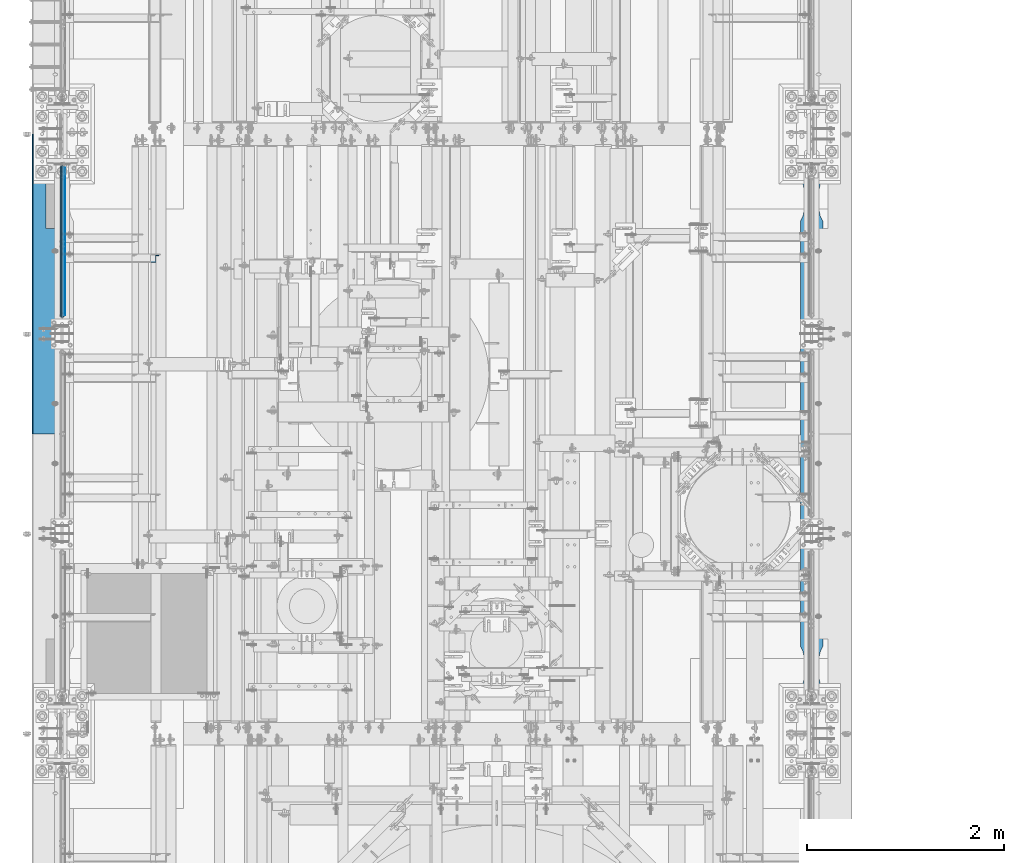
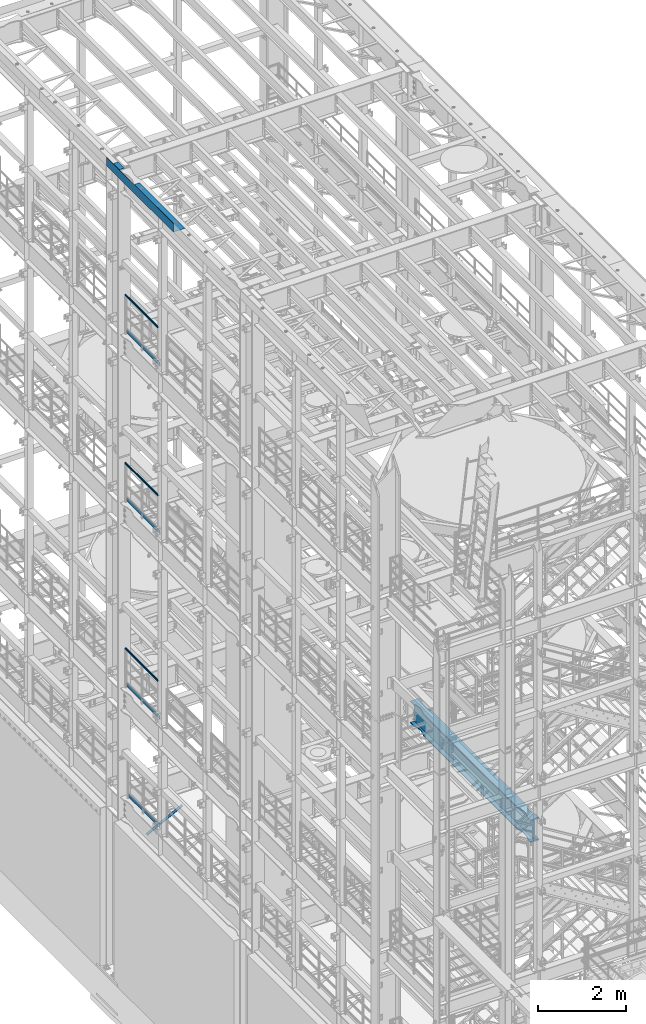
# One storey, part 1040 of 1876: 9 beams, 1 member, 7 elements without a shape of their own.
"""IFC2X3 building model written with IfcOpenShell, lengths in millimetres."""

from ifc_helpers import new_model, si_unit, frame, origin_with_axes, place, context, subcontext, project, spatial, faceted_brep, material, type_object, element, aggregate, save


model = new_model("IFC2X3")

# Units and contexts
model_context = context("Model", 3, precision=1e-05, world=origin_with_axes())
body_context = subcontext(model_context, "Body", "Model", "MODEL_VIEW")
ifc_project = project(units=[si_unit("LENGTHUNIT", "METRE", prefix="MILLI"), si_unit("AREAUNIT", "SQUARE_METRE"), si_unit("VOLUMEUNIT", "CUBIC_METRE"), si_unit("MASSUNIT", "GRAM", prefix="KILO"), si_unit("TIMEUNIT", "SECOND"), si_unit("PLANEANGLEUNIT", "RADIAN"), si_unit("SOLIDANGLEUNIT", "STERADIAN"), si_unit("THERMODYNAMICTEMPERATUREUNIT", "DEGREE_CELSIUS"), si_unit("LUMINOUSINTENSITYUNIT", "LUMEN")], contexts=[model_context])

# Site, building, storey
site_placement = place(None, origin_with_axes())
site = spatial("IfcSite", under=ifc_project, at=site_placement, CompositionType="ELEMENT")
building_placement = place(site_placement, origin_with_axes())
building = spatial("IfcBuilding", under=site, at=building_placement, Name="Undefined", CompositionType="ELEMENT")
storey_placement = place(building_placement, origin_with_axes())
storey = spatial("IfcBuildingStorey", under=building, at=storey_placement, Name="Undefined", CompositionType="ELEMENT", Elevation=0.0)

# Assembly, beam
assembly_1_placement = place(storey_placement, origin_with_axes())
assembly_1 = element("IfcElementAssembly", 1, at=assembly_1_placement, inside=storey, Name="RAIL", AssemblyPlace="NOTDEFINED", PredefinedType="RIGID_FRAME")
ifc_material_1 = material()
beam_type_1 = type_object("IfcBeamType", Name="PIPE1-1/2SCH40", PredefinedType="NOTDEFINED")
beam_1_placement = place(assembly_1_placement, frame((-1.81898940354586e-12, 5753.1, 19059.525), z_axis=(0.0, 0.0, -1.0), x_axis=(0.0, 1.0, 0.0)))
beam_1 = element("IfcBeam", 2, at=beam_1_placement, type_object=beam_type_1, material=ifc_material_1, Name="RAIL", ObjectType="PIPE1-1/2SCH40", context=body_context, shape_type="Brep", body=[
    faceted_brep([(24.1300000000001, -20.4469999999999, 0.0), (34.3535000000002, -17.7076214311803, 10.2235000000001), (1511.8715, -17.7076214311801, 10.2235000000001), (1522.095, -20.4470000000001, 0.0), (41.8376214311802, -10.2235000000001, 17.7076214311819), (1504.38737856882, -10.2235000000001, 17.7076214311819), (44.5770000000002, 0.0, 20.4470000000001), (1501.648, 0.0, 20.4470000000001), (41.8376214311802, 10.2235000000001, 17.7076214311819), (1504.38737856882, 10.2235000000001, 17.7076214311819), (34.3535000000002, 17.7076214311803, 10.2235000000001), (1511.8715, 17.7076214311801, 10.2235000000001), (24.1300000000001, 20.4469999999999, 0.0), (1522.095, 20.4470000000001, 0.0), (13.9065000000001, 17.7076214311803, -10.2235000000001), (1532.3185, 17.7076214311801, -10.2235000000001), (6.42237856882002, 10.2235000000001, -17.7076214311819), (1539.80262143118, 10.2235000000001, -17.7076214311819), (3.68299999999999, 0.0, -20.4470000000001), (1542.542, 0.0, -20.4470000000001), (6.42237856882002, -10.2235000000001, -17.7076214311819), (1539.80262143118, -10.2235000000001, -17.7076214311819), (13.9065000000001, -17.7076214311803, -10.2235000000001), (1532.3185, -17.7076214311801, -10.2235000000001), (24.1299999999854, -24.1299999999992, 0.0), (12.0650000000064, -20.8971929933177, -12.0649999999987), (1534.16, -20.8971929933186, -12.0649999999987), (1522.095, -24.1300000000001, 0.0), (3.23280700668147, -12.0650000000001, -20.8971929933177), (1542.99219299332, -12.0649999999996, -20.8971929933177), (-1.45519152283669e-11, 0.0, -24.130000000001), (1546.225, 0.0, -24.130000000001), (3.23280700668147, 12.0650000000001, -20.8971929933177), (1542.99219299332, 12.0649999999996, -20.8971929933177), (12.0650000000064, 20.8971929933177, -12.0649999999987), (1534.16, 20.8971929933186, -12.0649999999987), (24.1300000000047, 24.1299999999992, 0.0), (1522.095, 24.1300000000001, 0.0), (36.1949999999997, 20.8971929933184, 12.0649999999987), (1510.03, 20.8971929933186, 12.0649999999987), (45.0271929933187, 12.0650000000001, 20.8971929933177), (1501.19780700668, 12.0649999999996, 20.8971929933177), (48.2600000000002, 0.0, 24.130000000001), (1497.965, 0.0, 24.130000000001), (45.0271929933187, -12.0650000000001, 20.8971929933177), (1501.19780700668, -12.0649999999996, 20.8971929933177), (36.1949999999997, -20.8971929933184, 12.0649999999987), (1510.03, -20.8971929933186, 12.0649999999987)], [[[0, 1, 2, 3]], [[1, 4, 5, 2]], [[4, 6, 7, 5]], [[6, 8, 9, 7]], [[8, 10, 11, 9]], [[10, 12, 13, 11]], [[12, 14, 15, 13]], [[14, 16, 17, 15]], [[16, 18, 19, 17]], [[18, 20, 21, 19]], [[20, 22, 23, 21]], [[22, 0, 3, 23]], [[24, 25, 26, 27]], [[25, 28, 29, 26]], [[28, 30, 31, 29]], [[30, 32, 33, 31]], [[32, 34, 35, 33]], [[34, 36, 37, 35]], [[36, 38, 39, 37]], [[38, 40, 41, 39]], [[40, 42, 43, 41]], [[42, 44, 45, 43]], [[44, 46, 47, 45]], [[46, 24, 27, 47]], [[29, 31, 33, 35, 37, 39, 41, 43, 45, 47, 27, 26], [5, 7, 9, 11, 13, 15, 17, 19, 21, 23, 3, 2]], [[46, 44, 42, 40, 38, 36, 34, 32, 30, 28, 25, 24], [22, 20, 18, 16, 14, 12, 10, 8, 6, 4, 1, 0]]]),
])

assembly_2_placement = place(storey_placement, origin_with_axes())
assembly_2 = element("IfcElementAssembly", 3, at=assembly_2_placement, inside=storey, Name="RAIL", AssemblyPlace="NOTDEFINED", PredefinedType="RIGID_FRAME")
beam_2_placement = place(assembly_2_placement, frame((-1.81898940354586e-12, 5753.1, 14385.925), z_axis=(0.0, 0.0, -1.0), x_axis=(0.0, 1.0, 0.0)))
beam_2 = element("IfcBeam", 4, at=beam_2_placement, type_object=beam_type_1, material=ifc_material_1, Name="RAIL", ObjectType="PIPE1-1/2SCH40", context=body_context, shape_type="Brep", body=[
    faceted_brep([(24.1300000000001, -20.4469999999999, 0.0), (34.3535000000002, -17.7076214311803, 10.2235000000001), (1511.8715, -17.7076214311801, 10.2235000000001), (1522.095, -20.4470000000001, 0.0), (41.8376214311802, -10.2235000000001, 17.7076214311819), (1504.38737856882, -10.2235000000001, 17.7076214311819), (44.5770000000002, 0.0, 20.4470000000001), (1501.648, 0.0, 20.4470000000001), (41.8376214311802, 10.2235000000001, 17.7076214311819), (1504.38737856882, 10.2235000000001, 17.7076214311819), (34.3535000000002, 17.7076214311803, 10.2235000000001), (1511.8715, 17.7076214311801, 10.2235000000001), (24.1300000000001, 20.4469999999999, 0.0), (1522.095, 20.4470000000001, 0.0), (13.9065000000001, 17.7076214311803, -10.2235000000001), (1532.3185, 17.7076214311801, -10.2235000000001), (6.42237856882002, 10.2235000000001, -17.7076214311819), (1539.80262143118, 10.2235000000001, -17.7076214311819), (3.68299999999999, 0.0, -20.4470000000001), (1542.542, 0.0, -20.4470000000001), (6.42237856882002, -10.2235000000001, -17.7076214311819), (1539.80262143118, -10.2235000000001, -17.7076214311819), (13.9065000000001, -17.7076214311803, -10.2235000000001), (1532.3185, -17.7076214311801, -10.2235000000001), (24.1299999999854, -24.1299999999992, 0.0), (12.0650000000064, -20.8971929933177, -12.0649999999987), (1534.16, -20.8971929933186, -12.0649999999987), (1522.095, -24.1300000000001, 0.0), (3.23280700668147, -12.0650000000001, -20.8971929933177), (1542.99219299332, -12.0649999999996, -20.8971929933177), (-1.45519152283669e-11, 0.0, -24.130000000001), (1546.225, 0.0, -24.130000000001), (3.23280700668147, 12.0650000000001, -20.8971929933177), (1542.99219299332, 12.0649999999996, -20.8971929933177), (12.0650000000064, 20.8971929933177, -12.0649999999987), (1534.16, 20.8971929933186, -12.0649999999987), (24.1300000000047, 24.1299999999992, 0.0), (1522.095, 24.1300000000001, 0.0), (36.1949999999997, 20.8971929933184, 12.0649999999987), (1510.03, 20.8971929933186, 12.0649999999987), (45.0271929933187, 12.0650000000001, 20.8971929933177), (1501.19780700668, 12.0649999999996, 20.8971929933177), (48.2600000000002, 0.0, 24.130000000001), (1497.965, 0.0, 24.130000000001), (45.0271929933187, -12.0650000000001, 20.8971929933177), (1501.19780700668, -12.0649999999996, 20.8971929933177), (36.1949999999997, -20.8971929933184, 12.0649999999987), (1510.03, -20.8971929933186, 12.0649999999987)], [[[0, 1, 2, 3]], [[1, 4, 5, 2]], [[4, 6, 7, 5]], [[6, 8, 9, 7]], [[8, 10, 11, 9]], [[10, 12, 13, 11]], [[12, 14, 15, 13]], [[14, 16, 17, 15]], [[16, 18, 19, 17]], [[18, 20, 21, 19]], [[20, 22, 23, 21]], [[22, 0, 3, 23]], [[24, 25, 26, 27]], [[25, 28, 29, 26]], [[28, 30, 31, 29]], [[30, 32, 33, 31]], [[32, 34, 35, 33]], [[34, 36, 37, 35]], [[36, 38, 39, 37]], [[38, 40, 41, 39]], [[40, 42, 43, 41]], [[42, 44, 45, 43]], [[44, 46, 47, 45]], [[46, 24, 27, 47]], [[29, 31, 33, 35, 37, 39, 41, 43, 45, 47, 27, 26], [5, 7, 9, 11, 13, 15, 17, 19, 21, 23, 3, 2]], [[46, 44, 42, 40, 38, 36, 34, 32, 30, 28, 25, 24], [22, 20, 18, 16, 14, 12, 10, 8, 6, 4, 1, 0]]]),
])

assembly_3_placement = place(storey_placement, origin_with_axes())
assembly_3 = element("IfcElementAssembly", 5, at=assembly_3_placement, inside=storey, Name="RAIL", AssemblyPlace="NOTDEFINED", PredefinedType="RIGID_FRAME")
beam_3_placement = place(assembly_3_placement, frame((-1.81898940354586e-12, 5753.1, 9229.725), z_axis=(0.0, 0.0, -1.0), x_axis=(0.0, 1.0, 0.0)))
beam_3 = element("IfcBeam", 6, at=beam_3_placement, type_object=beam_type_1, material=ifc_material_1, Name="RAIL", ObjectType="PIPE1-1/2SCH40", context=body_context, shape_type="Brep", body=[
    faceted_brep([(24.1300000000001, -20.4469999999999, 0.0), (34.3535000000002, -17.7076214311803, 10.2235000000001), (1511.8715, -17.7076214311801, 10.2235000000001), (1522.095, -20.4470000000001, 0.0), (41.8376214311802, -10.2235000000001, 17.7076214311819), (1504.38737856882, -10.2235000000001, 17.7076214311819), (44.5770000000002, 0.0, 20.4470000000001), (1501.648, 0.0, 20.4470000000001), (41.8376214311802, 10.2235000000001, 17.7076214311819), (1504.38737856882, 10.2235000000001, 17.7076214311819), (34.3535000000002, 17.7076214311803, 10.2235000000001), (1511.8715, 17.7076214311801, 10.2235000000001), (24.1300000000001, 20.4469999999999, 0.0), (1522.095, 20.4470000000001, 0.0), (13.9065000000001, 17.7076214311803, -10.2235000000001), (1532.3185, 17.7076214311801, -10.2235000000001), (6.42237856882002, 10.2235000000001, -17.7076214311819), (1539.80262143118, 10.2235000000001, -17.7076214311819), (3.68299999999999, 0.0, -20.4470000000001), (1542.542, 0.0, -20.4470000000001), (6.42237856882002, -10.2235000000001, -17.7076214311819), (1539.80262143118, -10.2235000000001, -17.7076214311819), (13.9065000000001, -17.7076214311803, -10.2235000000001), (1532.3185, -17.7076214311801, -10.2235000000001), (24.1299999999854, -24.1299999999992, 0.0), (12.0650000000064, -20.8971929933177, -12.0649999999987), (1534.16, -20.8971929933186, -12.0649999999987), (1522.095, -24.1300000000001, 0.0), (3.23280700668147, -12.0650000000001, -20.8971929933177), (1542.99219299332, -12.0649999999996, -20.8971929933177), (-1.45519152283669e-11, 0.0, -24.130000000001), (1546.225, 0.0, -24.130000000001), (3.23280700668147, 12.0650000000001, -20.8971929933177), (1542.99219299332, 12.0649999999996, -20.8971929933177), (12.0650000000064, 20.8971929933177, -12.0649999999987), (1534.16, 20.8971929933186, -12.0649999999987), (24.1300000000047, 24.1299999999992, 0.0), (1522.095, 24.1300000000001, 0.0), (36.1949999999997, 20.8971929933184, 12.0649999999987), (1510.03, 20.8971929933186, 12.0649999999987), (45.0271929933187, 12.0650000000001, 20.8971929933177), (1501.19780700668, 12.0649999999996, 20.8971929933177), (48.2600000000002, 0.0, 24.130000000001), (1497.965, 0.0, 24.130000000001), (45.0271929933187, -12.0650000000001, 20.8971929933177), (1501.19780700668, -12.0649999999996, 20.8971929933177), (36.1949999999997, -20.8971929933184, 12.0649999999987), (1510.03, -20.8971929933186, 12.0649999999987)], [[[0, 1, 2, 3]], [[1, 4, 5, 2]], [[4, 6, 7, 5]], [[6, 8, 9, 7]], [[8, 10, 11, 9]], [[10, 12, 13, 11]], [[12, 14, 15, 13]], [[14, 16, 17, 15]], [[16, 18, 19, 17]], [[18, 20, 21, 19]], [[20, 22, 23, 21]], [[22, 0, 3, 23]], [[24, 25, 26, 27]], [[25, 28, 29, 26]], [[28, 30, 31, 29]], [[30, 32, 33, 31]], [[32, 34, 35, 33]], [[34, 36, 37, 35]], [[36, 38, 39, 37]], [[38, 40, 41, 39]], [[40, 42, 43, 41]], [[42, 44, 45, 43]], [[44, 46, 47, 45]], [[46, 24, 27, 47]], [[29, 31, 33, 35, 37, 39, 41, 43, 45, 47, 27, 26], [5, 7, 9, 11, 13, 15, 17, 19, 21, 23, 3, 2]], [[46, 44, 42, 40, 38, 36, 34, 32, 30, 28, 25, 24], [22, 20, 18, 16, 14, 12, 10, 8, 6, 4, 1, 0]]]),
])

# Beam
ifc_material_2 = material(Name="STEEL/A36")
beam_type_2 = type_object("IfcBeamType", PredefinedType="NOTDEFINED")
beam_4_placement = place(assembly_1_placement, frame((27.3049999999948, 5777.23, 18049.8809122948), z_axis=(0.0, 0.0, 1.0), x_axis=(0.0, 1.0, 0.0)))
beam_4 = element("IfcBeam", 7, at=beam_4_placement, type_object=beam_type_2, material=ifc_material_2, Name="PLATE", context=body_context, shape_type="Brep", body=[
    faceted_brep([(0.0, 3.17500000000018, -50.8000000000002), (0.0, 3.17500000000018, 50.8000000000002), (1497.965, 3.175, 50.7999999999993), (1497.965, 3.175, -50.7999999999993), (0.0, -3.17500000000018, 50.8000000000002), (1497.965, -3.175, 50.7999999999993), (0.0, -3.17500000000018, -50.8000000000002), (1497.965, -3.175, -50.7999999999993)], [[[0, 1, 2, 3]], [[1, 4, 5, 2]], [[4, 6, 7, 5]], [[6, 0, 3, 7]], [[5, 7, 3, 2]], [[6, 4, 1, 0]]]),
])

aggregate(assembly_1, [beam_4, beam_1])

beam_5_placement = place(assembly_2_placement, frame((27.3049999999948, 5777.23, 13376.2809122948), z_axis=(0.0, 0.0, 1.0), x_axis=(0.0, 1.0, 0.0)))
beam_5 = element("IfcBeam", 8, at=beam_5_placement, type_object=beam_type_2, material=ifc_material_2, Name="PLATE", context=body_context, shape_type="Brep", body=[
    faceted_brep([(0.0, 3.17500000000018, -50.8000000000002), (0.0, 3.17500000000018, 50.8000000000002), (1497.965, 3.175, 50.7999999999993), (1497.965, 3.175, -50.7999999999993), (0.0, -3.17500000000018, 50.8000000000002), (1497.965, -3.175, 50.7999999999993), (0.0, -3.17500000000018, -50.8000000000002), (1497.965, -3.175, -50.7999999999993)], [[[0, 1, 2, 3]], [[1, 4, 5, 2]], [[4, 6, 7, 5]], [[6, 0, 3, 7]], [[5, 7, 3, 2]], [[6, 4, 1, 0]]]),
])

aggregate(assembly_2, [beam_5, beam_2])

beam_6_placement = place(assembly_3_placement, frame((27.3049999999948, 5777.23, 8220.08091229478), z_axis=(0.0, 0.0, 1.0), x_axis=(0.0, 1.0, 0.0)))
beam_6 = element("IfcBeam", 9, at=beam_6_placement, type_object=beam_type_2, material=ifc_material_2, Name="PLATE", context=body_context, shape_type="Brep", body=[
    faceted_brep([(0.0, 3.17500000000018, -50.8000000000002), (0.0, 3.17500000000018, 50.8000000000002), (1497.965, 3.175, 50.7999999999993), (1497.965, 3.175, -50.7999999999993), (0.0, -3.17500000000018, 50.8000000000002), (1497.965, -3.175, 50.7999999999993), (0.0, -3.17500000000018, -50.8000000000002), (1497.965, -3.175, -50.7999999999993)], [[[0, 1, 2, 3]], [[1, 4, 5, 2]], [[4, 6, 7, 5]], [[6, 0, 3, 7]], [[5, 7, 3, 2]], [[6, 4, 1, 0]]]),
])

aggregate(assembly_3, [beam_6, beam_3])

# Assembly, beam
assembly_4_placement = place(storey_placement, origin_with_axes())
assembly_4 = element("IfcElementAssembly", 10, at=assembly_4_placement, inside=storey, Name="RAIL", AssemblyPlace="NOTDEFINED", PredefinedType="RIGID_FRAME")
beam_7_placement = place(assembly_4_placement, frame((27.3049999999948, 5777.22999999999, 5197.48091229478), z_axis=(0.0, 0.0, 1.0), x_axis=(0.0, 1.0, 0.0)))
beam_7 = element("IfcBeam", 11, at=beam_7_placement, type_object=beam_type_2, material=ifc_material_2, Name="PLATE", context=body_context, shape_type="Brep", body=[
    faceted_brep([(0.0, 3.17500000000018, -50.8000000000002), (0.0, 3.17500000000018, 50.8000000000002), (1402.6796633614, 3.175, 50.8000000000002), (1402.6796633614, 3.175, -50.8000000000002), (0.0, -3.17500000000018, 50.8000000000002), (1402.6796633614, -3.175, 50.8000000000002), (0.0, -3.17500000000018, -50.8000000000002), (1402.6796633614, -3.175, -50.8000000000002)], [[[0, 1, 2, 3]], [[1, 4, 5, 2]], [[4, 6, 7, 5]], [[6, 0, 3, 7]], [[5, 7, 3, 2]], [[6, 4, 1, 0]]]),
])
aggregate(assembly_4, [beam_7])

# Assembly, member
assembly_5_placement = place(storey_placement, origin_with_axes())
assembly_5 = element("IfcElementAssembly", 12, at=assembly_5_placement, inside=storey, AssemblyPlace="NOTDEFINED", PredefinedType="RIGID_FRAME")
member_type = type_object("IfcMemberType", Name="L3X3X3/8", PredefinedType="NOTDEFINED")
member_placement = place(assembly_5_placement, frame((17.6081923269563, 6353.175, 4576.47197854001), z_axis=(0.0, -1.0, 0.0), x_axis=(0.885896503105539, 0.0, 0.463882944055263)))
member = element("IfcMember", 13, at=member_placement, type_object=member_type, material=ifc_material_2, ObjectType="L3X3X3/8", context=body_context, shape_type="Brep", body=[
    faceted_brep([(22.4738417769599, 38.1000000000004, -38.0999999999999), (22.4738417769599, 38.1000000000004, 38.0999999999999), (1074.30197854536, 38.1000000002496, 38.0999999999999), (1074.30197854536, 38.1000000002496, -38.0999999999999), (22.4738417769613, 28.5749999999998, 38.0999999999999), (1074.30197854535, 28.5750000002463, 38.0999999999999), (22.4738417769613, 28.5749999999998, -28.5749999999998), (1074.30197854535, 28.5750000002463, -28.5749999999998), (22.4738417769699, -38.100000000004, -28.5749999999998), (1074.30197854533, -38.099999999773, -28.5749999999998), (22.4738417769699, -38.100000000004, -38.0999999999999), (1074.30197854533, -38.099999999773, -38.0999999999999)], [[[0, 1, 2, 3]], [[1, 4, 5, 2]], [[4, 6, 7, 5]], [[6, 8, 9, 7]], [[8, 10, 11, 9]], [[10, 0, 3, 11]], [[5, 7, 9, 11, 3, 2]], [[10, 8, 6, 4, 1, 0]]]),
])
aggregate(assembly_5, [member])

# Assembly, beam
assembly_6_placement = place(storey_placement, origin_with_axes())
assembly_6 = element("IfcElementAssembly", 14, at=assembly_6_placement, inside=storey, Name="BENT PLATE", AssemblyPlace="NOTDEFINED", PredefinedType="RIGID_FRAME")
beam_type_3 = type_object("IfcBeamType", PredefinedType="NOTDEFINED")
beam_8_placement = place(assembly_6_placement, frame((2.28578142867657e-05, 6096.0, 22558.3750000001), z_axis=(0.0, 1.0, 0.0), x_axis=(-0.999999999968684, 0.0, -7.91400000071008e-06)))
beam_8 = element("IfcBeam", 15, at=beam_8_placement, type_object=beam_type_3, material=ifc_material_2, Name="BENT PLATE", context=body_context, shape_type="Brep", body=[
    faceted_brep([(165.10005182243, -3.17500005134207, 561.975000000002), (165.100006108781, 3.17499994866375, 561.975000000002), (9.87827514231654e-10, 3.17499999999927, 561.975000000002), (-9.87827486476078e-10, -3.17500000000291, 561.975000000002), (165.10005182243, -3.17500005134207, 1235.07497558594), (165.100006108781, 3.17499994866375, 1235.07497558594), (-9.87827486476078e-10, -3.17500000000291, 1235.07497558594), (9.87827514231654e-10, 3.17499999999927, 1235.07497558594), (304.799984389467, -3.1750000948341, 1524.0), (304.799984389467, -3.1750000948341, -1524.0), (304.798604036541, 236.934982372881, -1524.0), (304.798604036052, 236.934982372997, 1524.0), (298.449951181141, 3.17499990714714, 1524.0), (-9.88620740827173e-10, 3.17500000000291, 1524.0), (9.877112461254e-10, -3.17499999999563, 1524.0), (298.448604036157, 236.934945778325, 1524.0), (298.449951181141, 3.17499990714714, -1524.0), (298.448604036646, 236.934945778212, -1524.0), (9.877112461254e-10, -3.17499999999563, -1524.0), (-9.88620740827173e-10, 3.17500000000291, -1524.0)], [[[0, 1, 2, 3]], [[4, 5, 1, 0]], [[6, 7, 5, 4]], [[8, 9, 10, 11]], [[12, 13, 14, 8, 11, 15]], [[16, 12, 15, 17]], [[11, 10, 17, 15]], [[9, 18, 19, 16, 17, 10]], [[19, 18, 3, 2]], [[13, 12, 16, 19, 2, 1, 5, 7]], [[14, 13, 7, 6]], [[3, 18, 9, 8, 14, 6, 4, 0]]]),
])
aggregate(assembly_6, [beam_8])

assembly_7_placement = place(storey_placement, origin_with_axes())
assembly_7 = element("IfcElementAssembly", 16, at=assembly_7_placement, inside=storey, Name="BEAM", AssemblyPlace="NOTDEFINED", PredefinedType="RIGID_FRAME")
ifc_material_3 = material(Name="STEEL/A992")
beam_type_4 = type_object("IfcBeamType", Name="W24X103", PredefinedType="NOTDEFINED")
beam_9_placement = place(assembly_7_placement, frame((7620.0, 1524.0, 4819.65), z_axis=(0.0, 0.0, 1.0), x_axis=(0.0, 1.0, 0.0)))
beam_9 = element("IfcBeam", 17, at=beam_9_placement, type_object=beam_type_4, material=ifc_material_3, Name="BEAM", ObjectType="W24X103", context=body_context, shape_type="Brep", body=[
    faceted_brep([(5789.6125, -7.14375000000018, -250.825000000001), (5797.55, 7.14375000000018, -250.825000000001), (5797.55, 7.14375000000018, 250.825000000001), (5789.6125, -7.14375000000018, 250.825000000001), (306.3875, -7.14375000000018, 250.825000000001), (298.45, 7.14375000000018, 250.825000000001), (298.45, 7.14375000000018, -250.825000000001), (306.3875, -7.14375000000018, -250.825000000001), (5797.55, -114.3, 285.75), (5797.55, -7.14375000000018, 285.75), (5797.55, 7.14375000000018, 285.75), (5797.55, 114.3, 285.75), (5782.88541369173, 114.29999927708, 311.150000000001), (5782.88541369173, -114.29999927708, 311.150000000001), (5641.97500876196, 114.299992330618, 311.150000000001), (5641.97500876196, 114.3, 285.75), (5592.87586146151, 88.8999957361821, 285.75), (5592.87586146151, 88.8999957361821, 311.150000000001), (5510.43685211057, 69.8863924058523, 285.75), (5510.43685211057, 69.8863924058523, 311.150000000001), (5426.0750039875, 63.5000040971918, 285.75), (5426.0750039875, 63.5000040971918, 311.150000000001), (5341.71315599965, 69.8863941921136, 285.75), (5341.71315599965, 69.8863941921136, 311.150000000001), (5259.2741470513, 88.8999992679901, 285.75), (5259.2741470513, 88.8999992679901, 311.150000000001), (5210.175, 114.3, 285.75), (5210.175, 114.3, 311.150000000001), (885.825008761703, 114.3, 285.75), (885.825008761703, 114.299990374483, 311.150000000001), (836.72586171043, 88.899989642473, 285.75), (836.72586171043, 88.899989642473, 311.150000000001), (754.286852762112, 69.8863845665965, 285.75), (754.286852762112, 69.8863845665965, 311.150000000001), (669.925004774302, 63.4999944716747, 285.75), (669.925004774302, 63.4999944716747, 311.150000000001), (585.563156651265, 69.8863827803352, 285.75), (585.563156651265, 69.8863827803352, 311.150000000001), (503.124147300347, 88.8999861106649, 285.75), (503.124147300347, 88.8999861106649, 311.150000000001), (454.024999999921, 114.3, 285.75), (454.024999999921, 114.3, 311.150000000001), (298.45, 114.3, 285.75), (313.114586308271, 114.3, 311.150000000001), (5641.97500876196, 114.299992330618, -285.75), (5641.97500876196, 114.3, -311.150000000001), (5592.87586146151, 88.8999957361821, -311.150000000001), (5592.87586146151, 88.8999957361821, -285.75), (5510.43685211057, 69.8863924058523, -311.150000000001), (5510.43685211057, 69.8863924058523, -285.75), (5426.0750039875, 63.5000040971918, -311.150000000001), (5426.0750039875, 63.5000040971918, -285.75), (5341.71315599965, 69.8863941921136, -311.150000000001), (5341.71315599965, 69.8863941921136, -285.75), (5259.2741470513, 88.8999992679901, -311.150000000001), (5259.2741470513, 88.8999992679901, -285.75), (5210.175, 114.3, -311.150000000001), (5210.175, 114.3, -285.75), (885.825008761703, 114.3, -311.150000000001), (885.825008761703, 114.299990374483, -285.75), (836.72586171043, 88.899989642473, -311.150000000001), (836.72586171043, 88.899989642473, -285.75), (754.286852762112, 69.8863845665965, -311.150000000001), (754.286852762112, 69.8863845665965, -285.75), (669.925004774302, 63.4999944716747, -311.150000000001), (669.925004774302, 63.4999944716747, -285.75), (585.563156651265, 69.8863827803352, -311.150000000001), (585.563156651265, 69.8863827803352, -285.75), (503.124147300347, 88.8999861106649, -311.150000000001), (503.124147300347, 88.8999861106649, -285.75), (454.024999999921, 114.3, -311.150000000001), (454.024999999921, 114.3, -285.75), (298.45, 114.3, -311.150000000001), (313.11459905754, 114.3, -285.75), (5641.97500876196, -114.299992330618, -285.75), (5592.87586146151, -88.8999957361821, -285.75), (5592.87586146151, -88.8999957361821, -311.150000000001), (5641.97500876196, -114.3, -311.150000000001), (5510.43685211057, -69.8863924058523, -285.75), (5510.43685211057, -69.8863924058523, -311.150000000001), (5426.0750039875, -63.5000040971918, -285.75), (5426.0750039875, -63.5000040971918, -311.150000000001), (5341.71315599965, -69.8863941921136, -285.75), (5341.71315599965, -69.8863941921136, -311.150000000001), (5259.2741470513, -88.8999992679901, -285.75), (5259.2741470513, -88.8999992679901, -311.150000000001), (5210.175, -114.3, -285.75), (5210.175, -114.3, -311.150000000001), (885.825008761703, -114.300009625517, -285.75), (885.825008761703, -114.3, -311.150000000001), (836.72586171043, -88.9000088935072, -285.75), (836.72586171043, -88.9000088935072, -311.150000000001), (754.286852762112, -69.8864038176307, -285.75), (754.286852762112, -69.8864038176307, -311.150000000001), (669.925004774302, -63.5000137227089, -285.75), (669.925004774302, -63.5000137227089, -311.150000000001), (585.563156651265, -69.8864020313695, -285.75), (585.563156651265, -69.8864020313695, -311.150000000001), (503.124147300347, -88.9000053616992, -285.75), (503.124147300347, -88.9000053616992, -311.150000000001), (454.024999999921, -114.3, -285.75), (454.024999999921, -114.3, -311.150000000001), (313.11459905754, -114.3, -285.75), (298.45, -114.3, -311.150000000001), (313.343799385621, -7.14375000000018, -285.35299987793), (313.343799385621, 7.14375000000018, -285.35299987793), (313.114599057541, 7.14375000000018, -285.75), (313.114599057541, -7.14375000000018, -285.75), (346.909996826172, -7.14375000000018, -285.35299987793), (346.909996826172, 7.14375000000018, -285.35299987793), (382.382251149282, -7.14375000000018, -269.000062630286), (382.382251149282, 7.14375000000018, -269.000062630286), (386.272459055476, -7.14375000000018, -265.703842989446), (386.272459055476, 7.14375000000018, -265.703842989446), (387.905124802588, -7.14375000000018, -260.873399528195), (387.905124802588, 7.14375000000018, -260.873399528195), (386.81238362386, -7.14375000000018, -255.89296800167), (386.81238362386, 7.14375000000018, -255.89296800167), (383.307376832887, -7.14375000000018, -252.189765486371), (383.307376832887, 7.14375000000018, -252.189765486371), (378.39451650093, -7.14375000000018, -250.825000000001), (378.39451650093, 7.14375000000018, -250.825000000001), (377.559514535493, -7.14375000000018, 250.825000000001), (377.559514535493, 7.14375000000018, 250.825000000001), (382.472374804242, -7.14375000000018, 252.189765448315), (382.472374804242, 7.14375000000018, 252.189765448315), (385.977381589376, -7.14375000000018, 255.892967871263), (385.977381589376, 7.14375000000018, 255.892967871263), (387.070122849314, -7.14375000000018, 260.873399307191), (387.070122849314, 7.14375000000018, 260.873399307191), (385.437457255921, -7.14375000000018, 265.703842745359), (385.437457255921, 7.14375000000018, 265.703842745359), (381.547249518856, -7.14375000000018, 269.000062475843), (381.547249518856, 7.14375000000018, 269.000062475843), (346.074998474121, -7.14375000000018, 285.35299987793), (346.074998474121, 7.14375000000018, 285.35299987793), (298.45, -7.14375000000018, 285.35299987793), (298.45, 7.14375000000018, 285.35299987793), (298.45, -7.14375000000018, 285.75), (298.45, 7.14375000000018, 285.75), (313.114586308271, -114.3, 311.150000000001), (298.45, -114.3, 285.75), (454.024999999921, -114.3, 285.75), (454.024999999921, -114.3, 311.150000000001), (503.124147300347, -88.9000053616992, 285.75), (503.124147300347, -88.9000053616992, 311.150000000001), (585.563156651265, -69.8864020313695, 285.75), (585.563156651265, -69.8864020313695, 311.150000000001), (669.925004774302, -63.5000137227089, 285.75), (669.925004774302, -63.5000137227089, 311.150000000001), (754.286852762112, -69.8864038176307, 285.75), (754.286852762112, -69.8864038176307, 311.150000000001), (836.72586171043, -88.9000088935072, 285.75), (836.72586171043, -88.9000088935072, 311.150000000001), (885.825008761703, -114.300009625517, 311.150000000001), (885.825008761703, -114.3, 285.75), (5210.175, -114.3, 285.75), (5210.175, -114.3, 311.150000000001), (5259.2741470513, -88.8999992679901, 285.75), (5259.2741470513, -88.8999992679901, 311.150000000001), (5341.71315599965, -69.8863941921136, 285.75), (5341.71315599965, -69.8863941921136, 311.150000000001), (5426.0750039875, -63.5000040971918, 285.75), (5426.0750039875, -63.5000040971918, 311.150000000001), (5510.43685211057, -69.8863924058523, 285.75), (5510.43685211057, -69.8863924058523, 311.150000000001), (5592.87586146151, -88.8999957361821, 285.75), (5592.87586146151, -88.8999957361821, 311.150000000001), (5641.97500876196, -114.299992330618, 311.150000000001), (5641.97500876196, -114.3, 285.75), (5797.55, -7.14375000000018, 285.35299987793), (5797.55, 7.14375000000018, 285.35299987793), (5749.92500152588, -7.14375000000018, 285.35299987793), (5749.92500152588, 7.14375000000018, 285.35299987793), (5714.45275048114, -7.14375000000018, 269.000062475843), (5714.45275048114, 7.14375000000018, 269.000062475843), (5710.56254274408, -7.14375000000018, 265.703842745359), (5710.56254274408, 7.14375000000018, 265.703842745359), (5708.92987715069, -7.14375000000018, 260.873399307191), (5708.92987715069, 7.14375000000018, 260.873399307191), (5710.02261841062, -7.14375000000018, 255.892967871263), (5710.02261841062, 7.14375000000018, 255.892967871263), (5713.52762519576, -7.14375000000018, 252.189765448315), (5713.52762519576, 7.14375000000018, 252.189765448315), (5718.44048546451, -7.14375000000018, 250.825000000001), (5718.44048546451, 7.14375000000018, 250.825000000001), (5717.60548349907, -7.14375000000018, -250.825000000001), (5717.60548349907, 7.14375000000018, -250.825000000001), (5712.69262316711, -7.14375000000018, -252.189765486371), (5712.69262316711, 7.14375000000018, -252.189765486371), (5709.18761637614, -7.14375000000018, -255.89296800167), (5709.18761637614, 7.14375000000018, -255.89296800167), (5708.09487519741, -7.14375000000018, -260.873399528195), (5708.09487519741, 7.14375000000018, -260.873399528195), (5709.72754094452, -7.14375000000018, -265.703842989446), (5709.72754094452, 7.14375000000018, -265.703842989446), (5713.61774885072, -7.14375000000018, -269.000062630286), (5713.61774885072, 7.14375000000018, -269.000062630286), (5749.09000317383, -7.14375000000018, -285.35299987793), (5749.09000317383, 7.14375000000018, -285.35299987793), (5782.65620061438, -7.14375000000018, -285.35299987793), (5782.65620061438, 7.14375000000018, -285.35299987793), (5782.88540094246, 7.14375000000018, -285.75), (5782.88540094246, 114.299999277079, -285.75), (5797.55, 114.3, -311.150000000001), (5797.55, -114.3, -311.150000000001), (5782.88540094246, -114.299999277079, -285.75), (5782.88540094246, -7.14375000000018, -285.75)], [[[0, 1, 2, 3]], [[4, 5, 6, 7]], [[8, 9, 10, 11, 12, 13]], [[14, 15, 16, 17]], [[17, 16, 18, 19]], [[19, 18, 20, 21]], [[21, 20, 22, 23]], [[23, 22, 24, 25]], [[25, 24, 26, 27]], [[27, 26, 28, 29]], [[29, 28, 30, 31]], [[31, 30, 32, 33]], [[33, 32, 34, 35]], [[35, 34, 36, 37]], [[37, 36, 38, 39]], [[39, 38, 40, 41]], [[41, 40, 42, 43]], [[44, 45, 46, 47]], [[47, 46, 48, 49]], [[49, 48, 50, 51]], [[51, 50, 52, 53]], [[53, 52, 54, 55]], [[55, 54, 56, 57]], [[57, 56, 58, 59]], [[59, 58, 60, 61]], [[61, 60, 62, 63]], [[63, 62, 64, 65]], [[65, 64, 66, 67]], [[67, 66, 68, 69]], [[69, 68, 70, 71]], [[71, 70, 72, 73]], [[74, 75, 76, 77]], [[78, 79, 76, 75]], [[80, 81, 79, 78]], [[82, 83, 81, 80]], [[84, 85, 83, 82]], [[86, 87, 85, 84]], [[87, 86, 88, 89]], [[88, 90, 91, 89]], [[92, 93, 91, 90]], [[94, 95, 93, 92]], [[96, 97, 95, 94]], [[98, 99, 97, 96]], [[100, 101, 99, 98]], [[101, 100, 102, 103]], [[104, 105, 106, 73, 72, 103, 102, 107]], [[108, 109, 105, 104]], [[110, 111, 109, 108]], [[112, 113, 111, 110]], [[114, 115, 113, 112]], [[116, 117, 115, 114]], [[118, 119, 117, 116]], [[120, 121, 119, 118]], [[121, 120, 7, 6]], [[122, 123, 5, 4]], [[124, 125, 123, 122]], [[126, 127, 125, 124]], [[128, 129, 127, 126]], [[130, 131, 129, 128]], [[132, 133, 131, 130]], [[134, 135, 133, 132]], [[135, 134, 136, 137]], [[137, 136, 138, 139]], [[140, 43, 42, 139, 138, 141]], [[142, 143, 140, 141]], [[143, 142, 144, 145]], [[145, 144, 146, 147]], [[147, 146, 148, 149]], [[149, 148, 150, 151]], [[151, 150, 152, 153]], [[154, 153, 152, 155]], [[156, 157, 154, 155]], [[157, 156, 158, 159]], [[159, 158, 160, 161]], [[161, 160, 162, 163]], [[163, 162, 164, 165]], [[165, 164, 166, 167]], [[168, 167, 166, 169]], [[168, 169, 8, 13]], [[14, 17, 19, 21, 23, 25, 27, 29, 31, 33, 35, 37, 39, 41, 43, 140, 143, 145, 147, 149, 151, 153, 154, 157, 159, 161, 163, 165, 167, 168, 13, 12]], [[15, 14, 12, 11]], [[139, 42, 40, 38, 36, 34, 32, 30, 28, 26, 24, 22, 20, 18, 16, 15, 11, 10]], [[170, 171, 10, 9]], [[172, 173, 171, 170]], [[174, 175, 173, 172]], [[176, 177, 175, 174]], [[178, 179, 177, 176]], [[180, 181, 179, 178]], [[182, 183, 181, 180]], [[184, 185, 183, 182]], [[185, 184, 3, 2]], [[186, 187, 1, 0]], [[188, 189, 187, 186]], [[190, 191, 189, 188]], [[192, 193, 191, 190]], [[194, 195, 193, 192]], [[196, 197, 195, 194]], [[198, 199, 197, 196]], [[199, 198, 200, 201]], [[106, 105, 109, 111, 113, 115, 117, 119, 121, 6, 5, 123, 125, 127, 129, 131, 133, 135, 137, 139, 10, 171, 173, 175, 177, 179, 181, 183, 185, 2, 1, 187, 189, 191, 193, 195, 197, 199, 201, 202]], [[44, 47, 49, 51, 53, 55, 57, 59, 61, 63, 65, 67, 69, 71, 73, 106, 202, 203]], [[45, 44, 203, 204]], [[77, 76, 79, 81, 83, 85, 87, 89, 91, 93, 95, 97, 99, 101, 103, 72, 70, 68, 66, 64, 62, 60, 58, 56, 54, 52, 50, 48, 46, 45, 204, 205]], [[74, 77, 205, 206]], [[107, 102, 100, 98, 96, 94, 92, 90, 88, 86, 84, 82, 80, 78, 75, 74, 206, 207]], [[205, 204, 203, 202, 201, 200, 207, 206]], [[184, 182, 180, 178, 176, 174, 172, 170, 9, 138, 136, 134, 132, 130, 128, 126, 124, 122, 4, 7, 120, 118, 116, 114, 112, 110, 108, 104, 107, 207, 200, 198, 196, 194, 192, 190, 188, 186, 0, 3]], [[169, 166, 164, 162, 160, 158, 156, 155, 152, 150, 148, 146, 144, 142, 141, 138, 9, 8]]]),
])
aggregate(assembly_7, [beam_9])

save(model, "model.ifc")
